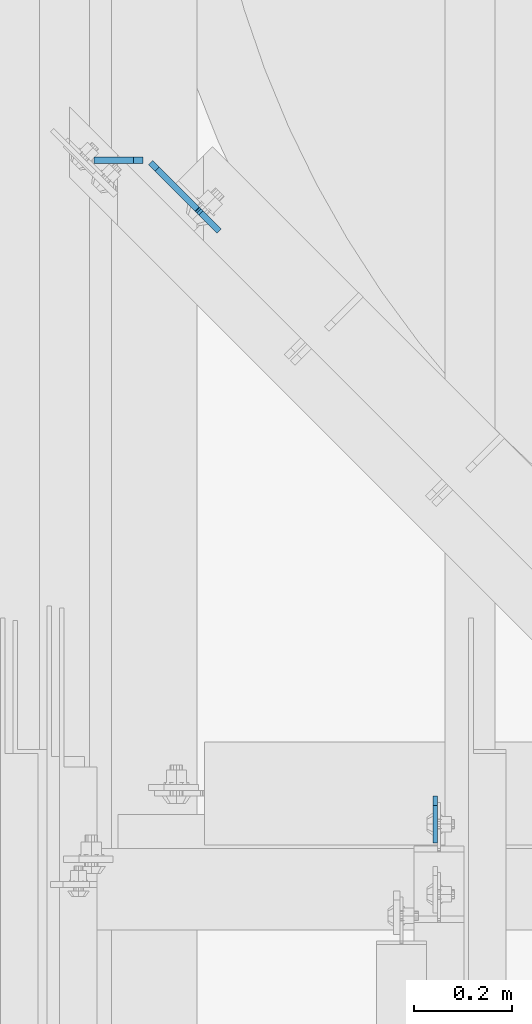
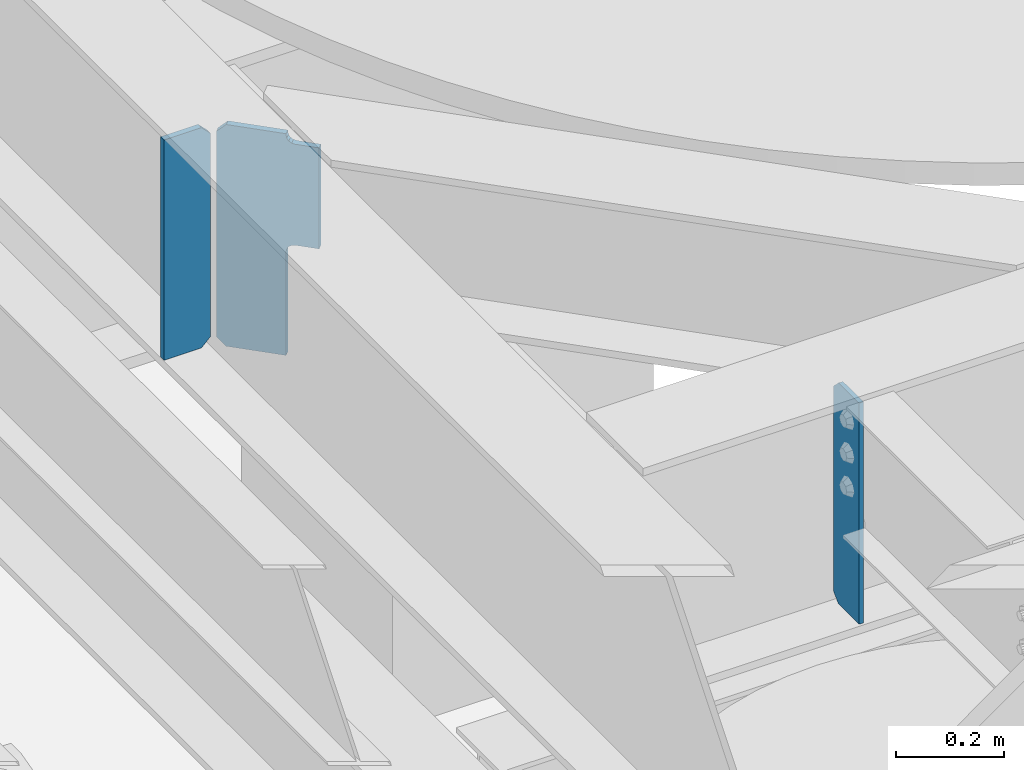
# One storey, part 1490 of 1876: 3 plates, 2 elements without a shape of their own.
"""IFC2X3 building model written with IfcOpenShell, lengths in millimetres."""

from ifc_helpers import new_model, si_unit, frame, origin_with_axes, place, context, subcontext, project, spatial, faceted_brep, material, type_object, element, aggregate, save


model = new_model("IFC2X3")

# Units and contexts
model_context = context("Model", 3, precision=1e-05, world=origin_with_axes())
body_context = subcontext(model_context, "Body", "Model", "MODEL_VIEW")
ifc_project = project(units=[si_unit("LENGTHUNIT", "METRE", prefix="MILLI"), si_unit("AREAUNIT", "SQUARE_METRE"), si_unit("VOLUMEUNIT", "CUBIC_METRE"), si_unit("MASSUNIT", "GRAM", prefix="KILO"), si_unit("TIMEUNIT", "SECOND"), si_unit("PLANEANGLEUNIT", "RADIAN"), si_unit("SOLIDANGLEUNIT", "STERADIAN"), si_unit("THERMODYNAMICTEMPERATUREUNIT", "DEGREE_CELSIUS"), si_unit("LUMINOUSINTENSITYUNIT", "LUMEN")], contexts=[model_context])

# Site, building, storey
site_placement = place(None, origin_with_axes())
site = spatial("IfcSite", under=ifc_project, at=site_placement, CompositionType="ELEMENT")
building_placement = place(site_placement, origin_with_axes())
building = spatial("IfcBuilding", under=site, at=building_placement, Name="Undefined", CompositionType="ELEMENT")
storey_placement = place(building_placement, origin_with_axes())
storey = spatial("IfcBuildingStorey", under=building, at=storey_placement, Name="Undefined", CompositionType="ELEMENT", Elevation=0.0)

# Assembly, plate
assembly_1_placement = place(storey_placement, origin_with_axes())
assembly_1 = element("IfcElementAssembly", 1, at=assembly_1_placement, inside=storey, Name="BEAM", AssemblyPlace="NOTDEFINED", PredefinedType="RIGID_FRAME")
ifc_material = material(Name="STEEL/A36")
plate_type_1 = type_object("IfcPlateType", PredefinedType="NOTDEFINED")
plate_1_placement = place(assembly_1_placement, frame((2786.06200006928, -3753.64375, 7635.875), z_axis=(0.0, 0.0, 1.0), x_axis=(0.0, -1.0, 0.0)))
plate_1 = element("IfcPlate", 2, at=plate_1_placement, type_object=plate_type_1, material=ifc_material, Name="PLATE", context=body_context, shape_type="Brep", body=[
    faceted_brep([(0.0, -4.76249999999982, 19.0499992370605), (0.0, -4.76249999999982, 481.012500762939), (0.0, 4.76249999999982, 481.012500762939), (0.0, 4.76249999999982, 19.0499992370605), (19.0499992370605, -4.76249999999982, 500.0625), (19.0499992370605, 4.76249999999982, 500.0625), (95.25, -4.76249999999982, 500.0625), (95.25, 4.76249999999982, 500.0625), (95.25, -4.76249999999982, 0.0), (95.25, 4.76249999999982, 0.0), (19.0499992370605, -4.76249999999982, 0.0), (19.0499992370605, 4.76249999999982, 0.0)], [[[0, 1, 2, 3]], [[1, 4, 5, 2]], [[4, 6, 7, 5]], [[6, 8, 9, 7]], [[8, 10, 11, 9]], [[10, 0, 3, 11]], [[5, 7, 9, 11, 3, 2]], [[10, 8, 6, 4, 1, 0]]]),
])
aggregate(assembly_1, [plate_1])

# Assembly, plates
assembly_2_placement = place(storey_placement, origin_with_axes())
assembly_2 = element("IfcElementAssembly", 3, at=assembly_2_placement, inside=storey, Name="BEAM", AssemblyPlace="NOTDEFINED", PredefinedType="RIGID_FRAME")
plate_type_2 = type_object("IfcPlateType", PredefinedType="NOTDEFINED")
plate_2_placement = place(assembly_2_placement, frame((2191.54375, -2460.1989146259, 7635.875), z_axis=(0.0, 0.0, 1.0), x_axis=(-1.0, 0.0, 0.0)))
plate_2 = element("IfcPlate", 4, at=plate_2_placement, type_object=plate_type_2, material=ifc_material, Name="PLATE", context=body_context, shape_type="Brep", body=[
    faceted_brep([(0.0, -6.35000000000196, 19.0499992370605), (0.0, -6.34999999999991, 479.425006866455), (0.0, 6.34999999999991, 479.425006866455), (0.0, 6.35000000000105, 19.0499992370605), (19.0499992370605, -6.34999999999991, 498.475006103516), (19.0499992370605, 6.34999999999991, 498.475006103516), (99.21875, -6.34999999999991, 498.475006103516), (99.21875, 6.34999999999991, 498.475006103516), (99.21875, -6.34999999999991, 0.0), (99.21875, 6.34999999999991, 0.0), (19.0499992370642, -6.35000000000105, 0.0), (19.0499992370633, 6.35000000000105, 0.0)], [[[0, 1, 2, 3]], [[1, 4, 5, 2]], [[4, 6, 7, 5]], [[6, 8, 9, 7]], [[8, 10, 11, 9]], [[10, 0, 3, 11]], [[5, 7, 9, 11, 3, 2]], [[10, 8, 6, 4, 1, 0]]]),
])
plate_type_3 = type_object("IfcPlateType", PredefinedType="NOTDEFINED")
plate_3_placement = place(assembly_2_placement, frame((2207.14637724102, -2464.68904040117, 7653.3375), z_axis=(0.500000083934032, -0.499999915934031, 0.707106781279831), x_axis=(0.500000084065953, -0.499999916065956, -0.707106781093264)))
plate_3 = element("IfcPlate", 5, at=plate_3_placement, type_object=plate_type_3, material=ifc_material, Name="PLATE", context=body_context, shape_type="Brep", body=[
    faceted_brep([(0.0, -6.35000000000036, 0.0), (-327.779357909983, -6.34999999999945, 327.779357910018), (-327.779357909984, 6.34999999999945, 327.779357910018), (0.0, 6.35000000000036, 0.0), (-327.779357909974, -6.34999999999673, 354.720123290871), (-327.779357909975, 6.35000000000218, 354.72012329087), (-246.521087646294, -6.34999999997945, 435.978363036958), (-246.521087646295, 6.35000000001946, 435.978363036957), (-244.276026676376, -6.34999999997945, 433.733304414544), (-244.276026676377, 6.35000000001855, 433.733304414543), (-238.610784886918, -6.34999999997945, 429.947914446682), (-238.610784886918, 6.35000000001946, 429.947914446682), (-231.928178155422, -6.34999999997854, 428.618663148393), (-231.928178155423, 6.35000000001946, 428.618663148392), (-225.245571892809, -6.34999999997763, 429.947916803919), (-225.24557189281, 6.35000000001946, 429.947916803918), (-219.580331438615, -6.34999999997672, 433.73330877015), (-219.580331438616, 6.35000000002219, 433.73330877015), (-187.068817138485, -6.34999999997035, 466.244812011571), (-187.068817138485, 6.35000000002856, 466.244812011571), (-25.4242095946238, -6.34999999997035, 304.600189208904), (-25.4242095946247, 6.35000000002856, 304.600189208903), (-57.9357132390196, -6.34999999997672, 272.088696623216), (-57.9357132390196, 6.35000000002128, 272.088696623214), (-61.7211085739791, -6.34999999997763, 266.423453976015), (-61.72110857398, 6.35000000002128, 266.423453976014), (-63.0503630608664, -6.34999999997854, 259.740844111398), (-63.0503630608673, 6.35000000002037, 259.740844111397), (-61.7211097105192, -6.34999999997945, 253.058234020711), (-61.7211097105201, 6.35000000001946, 253.058234020711), (-57.935715339072, -6.34999999997945, 247.392990729717), (-57.9357153390729, 6.35000000001855, 247.392990729716), (108.199020385746, -6.34999999997854, 81.258255004881), (108.199020385745, 6.35000000001946, 81.258255004881), (26.9407691955512, -6.34999999999582, 4.54747350886464e-12), (26.9407691955503, 6.35000000000309, 3.63797880709171e-12)], [[[0, 1, 2, 3]], [[1, 4, 5, 2]], [[4, 6, 7, 5]], [[6, 8, 9, 7]], [[8, 10, 11, 9]], [[10, 12, 13, 11]], [[12, 14, 15, 13]], [[14, 16, 17, 15]], [[16, 18, 19, 17]], [[18, 20, 21, 19]], [[20, 22, 23, 21]], [[22, 24, 25, 23]], [[24, 26, 27, 25]], [[26, 28, 29, 27]], [[28, 30, 31, 29]], [[30, 32, 33, 31]], [[32, 34, 35, 33]], [[34, 0, 3, 35]], [[5, 7, 9, 11, 13, 15, 17, 19, 21, 23, 25, 27, 29, 31, 33, 35, 3, 2]], [[34, 32, 30, 28, 26, 24, 22, 20, 18, 16, 14, 12, 10, 8, 6, 4, 1, 0]]]),
])
aggregate(assembly_2, [plate_2, plate_3])

save(model, "model.ifc")
